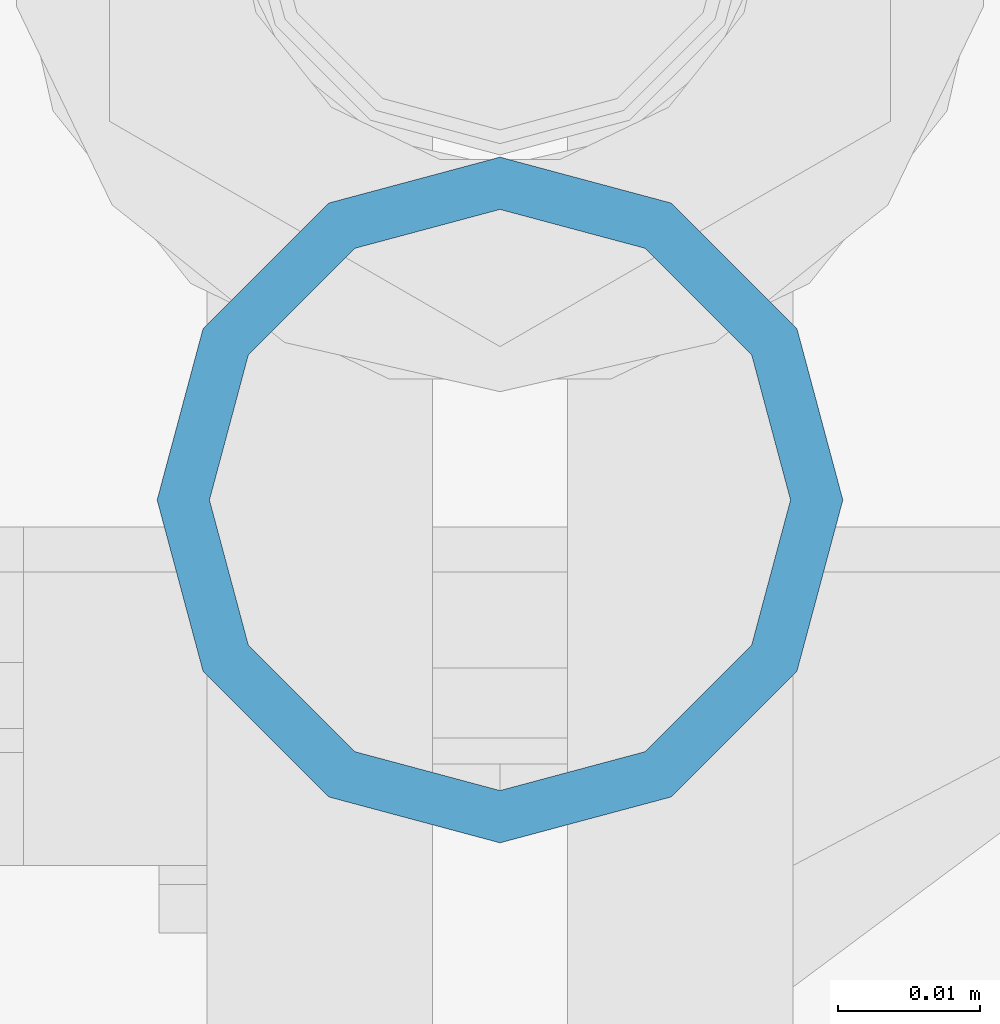
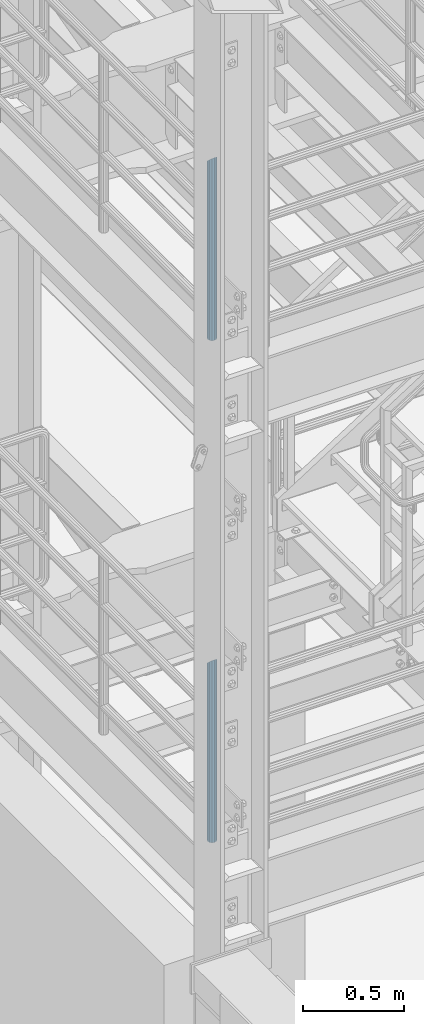
# One storey, part 564 of 1876: 2 columns, 2 elements without a shape of their own.
"""IFC2X3 building model written with IfcOpenShell, lengths in millimetres."""

from ifc_helpers import new_model, si_unit, frame, origin_with_axes, place, context, subcontext, project, spatial, faceted_brep, material, type_object, element, aggregate, save


model = new_model("IFC2X3")

# Units and contexts
model_context = context("Model", 3, precision=1e-05, world=origin_with_axes())
body_context = subcontext(model_context, "Body", "Model", "MODEL_VIEW")
ifc_project = project(units=[si_unit("LENGTHUNIT", "METRE", prefix="MILLI"), si_unit("AREAUNIT", "SQUARE_METRE"), si_unit("VOLUMEUNIT", "CUBIC_METRE"), si_unit("MASSUNIT", "GRAM", prefix="KILO"), si_unit("TIMEUNIT", "SECOND"), si_unit("PLANEANGLEUNIT", "RADIAN"), si_unit("SOLIDANGLEUNIT", "STERADIAN"), si_unit("THERMODYNAMICTEMPERATUREUNIT", "DEGREE_CELSIUS"), si_unit("LUMINOUSINTENSITYUNIT", "LUMEN")], contexts=[model_context])

# Site, building, storey
site_placement = place(None, origin_with_axes())
site = spatial("IfcSite", under=ifc_project, at=site_placement, CompositionType="ELEMENT")
building_placement = place(site_placement, origin_with_axes())
building = spatial("IfcBuilding", under=site, at=building_placement, Name="Undefined", CompositionType="ELEMENT")
storey_placement = place(building_placement, origin_with_axes())
storey = spatial("IfcBuildingStorey", under=building, at=storey_placement, Name="Undefined", CompositionType="ELEMENT", Elevation=0.0)

# Assembly, column
assembly_1_placement = place(storey_placement, origin_with_axes())
assembly_1 = element("IfcElementAssembly", 1, at=assembly_1_placement, inside=storey, Name="RAIL", AssemblyPlace="NOTDEFINED", PredefinedType="RIGID_FRAME")
ifc_material = material()
column_type = type_object("IfcColumnType", Name="PIPE1-1/2SCH40", PredefinedType="NOTDEFINED")
column_1_placement = place(assembly_1_placement, frame((2.72848410531878e-12, -6925.945, 8153.4), z_axis=(0.0, 1.0, 0.0), x_axis=(0.0, 0.0, 1.0)))
column_1 = element("IfcColumn", 2, at=column_1_placement, type_object=column_type, material=ifc_material, Name="POST", ObjectType="PIPE1-1/2SCH40", context=body_context, shape_type="Brep", body=[
    faceted_brep([(0.0, -20.4469999999999, 0.0), (0.0, -17.7076214311803, 10.2235000000001), (1066.1015, -17.7076214311803, 10.2235000000001), (1076.325, -20.4469999999999, 0.0), (0.0, -10.2235000000001, 17.7076214311801), (1058.61737856882, -10.2235000000001, 17.7076214311801), (-1.45519152283669e-11, 0.0, 20.4470000000001), (1055.878, 0.0, 20.4470000000001), (0.0, 10.2235000000001, 17.7076214311801), (1058.61737856882, 10.2235000000001, 17.7076214311801), (0.0, 17.7076214311803, 10.2235000000001), (1066.1015, 17.7076214311803, 10.2235000000001), (0.0, 20.4469999999999, 0.0), (1076.325, 20.4469999999999, 0.0), (0.0, 17.7076214311803, -10.2235000000001), (1086.5485, 17.7076214311803, -10.2235000000001), (0.0, 10.2235000000001, -17.7076214311801), (1094.03262143118, 10.2235000000001, -17.7076214311801), (-1.45519152283669e-11, 0.0, -20.4470000000001), (1096.772, 0.0, -20.4470000000001), (0.0, -10.2235000000001, -17.7076214311801), (1094.03262143118, -10.2235000000001, -17.7076214311801), (0.0, -17.7076214311803, -10.2235000000001), (1086.5485, -17.7076214311803, -10.2235000000001), (0.0, -24.1299999999992, 0.0), (0.0, -20.8971929933184, -12.0649999999996), (1088.39, -20.8971929933184, -12.0649999999996), (1076.325, -24.1300000000001, 0.0), (0.0, -12.0650000000001, -20.8971929933186), (1097.22219299332, -12.0650000000001, -20.8971929933186), (-1.45519152283669e-11, 0.0, -24.130000000001), (1100.455, 0.0, -24.1300000000001), (0.0, 12.0650000000001, -20.8971929933186), (1097.22219299332, 12.0650000000001, -20.8971929933186), (0.0, 20.8971929933184, -12.0649999999996), (1088.39, 20.8971929933184, -12.0649999999996), (0.0, 24.1299999999992, 0.0), (1076.325, 24.1300000000001, 0.0), (0.0, 20.8971929933184, 12.0649999999996), (1064.26, 20.8971929933184, 12.0649999999996), (0.0, 12.0650000000001, 20.8971929933186), (1055.42780700668, 12.0650000000001, 20.8971929933186), (-1.45519152283669e-11, 0.0, 24.130000000001), (1052.195, 0.0, 24.1300000000001), (0.0, -12.0650000000001, 20.8971929933186), (1055.42780700668, -12.0650000000001, 20.8971929933186), (0.0, -20.8971929933184, 12.0649999999996), (1064.26, -20.8971929933184, 12.0649999999996)], [[[0, 1, 2, 3]], [[1, 4, 5, 2]], [[4, 6, 7, 5]], [[6, 8, 9, 7]], [[8, 10, 11, 9]], [[10, 12, 13, 11]], [[12, 14, 15, 13]], [[14, 16, 17, 15]], [[16, 18, 19, 17]], [[18, 20, 21, 19]], [[20, 22, 23, 21]], [[22, 0, 3, 23]], [[24, 25, 26, 27]], [[25, 28, 29, 26]], [[28, 30, 31, 29]], [[30, 32, 33, 31]], [[32, 34, 35, 33]], [[34, 36, 37, 35]], [[36, 38, 39, 37]], [[38, 40, 41, 39]], [[40, 42, 43, 41]], [[42, 44, 45, 43]], [[44, 46, 47, 45]], [[46, 24, 27, 47]], [[29, 31, 33, 35, 37, 39, 41, 43, 45, 47, 27, 26], [5, 7, 9, 11, 13, 15, 17, 19, 21, 23, 3, 2]], [[46, 44, 42, 40, 38, 36, 34, 32, 30, 28, 25, 24], [22, 20, 18, 16, 14, 12, 10, 8, 6, 4, 1, 0]]]),
])
aggregate(assembly_1, [column_1])

assembly_2_placement = place(storey_placement, origin_with_axes())
assembly_2 = element("IfcElementAssembly", 3, at=assembly_2_placement, inside=storey, Name="RAIL", AssemblyPlace="NOTDEFINED", PredefinedType="RIGID_FRAME")
column_2_placement = place(assembly_2_placement, frame((2.72848410531878e-12, -6925.945, 5130.80000212598), z_axis=(0.0, 1.0, 0.0), x_axis=(0.0, 0.0, 1.0)))
column_2 = element("IfcColumn", 4, at=column_2_placement, type_object=column_type, material=ifc_material, Name="POST", ObjectType="PIPE1-1/2SCH40", context=body_context, shape_type="Brep", body=[
    faceted_brep([(0.0, -20.4469999999999, 0.0), (0.0, -17.7076214311803, 10.2235000000001), (1066.1015, -17.7076214311803, 10.2235000000001), (1076.325, -20.4469999999999, 0.0), (0.0, -10.2235000000001, 17.7076214311801), (1058.61737856882, -10.2235000000001, 17.7076214311801), (-1.45519152283669e-11, 0.0, 20.4470000000001), (1055.878, 0.0, 20.4470000000001), (0.0, 10.2235000000001, 17.7076214311801), (1058.61737856882, 10.2235000000001, 17.7076214311801), (0.0, 17.7076214311803, 10.2235000000001), (1066.1015, 17.7076214311803, 10.2235000000001), (0.0, 20.4469999999999, 0.0), (1076.325, 20.4469999999999, 0.0), (0.0, 17.7076214311803, -10.2235000000001), (1086.5485, 17.7076214311803, -10.2235000000001), (0.0, 10.2235000000001, -17.7076214311801), (1094.03262143118, 10.2235000000001, -17.7076214311801), (-1.45519152283669e-11, 0.0, -20.4470000000001), (1096.772, 0.0, -20.4470000000001), (0.0, -10.2235000000001, -17.7076214311801), (1094.03262143118, -10.2235000000001, -17.7076214311801), (0.0, -17.7076214311803, -10.2235000000001), (1086.5485, -17.7076214311803, -10.2235000000001), (0.0, -24.1299999999992, 0.0), (0.0, -20.8971929933184, -12.0649999999996), (1088.39, -20.8971929933184, -12.0649999999996), (1076.325, -24.1300000000001, 0.0), (0.0, -12.0650000000001, -20.8971929933186), (1097.22219299332, -12.0650000000001, -20.8971929933186), (-1.45519152283669e-11, 0.0, -24.130000000001), (1100.455, 0.0, -24.1300000000001), (0.0, 12.0650000000001, -20.8971929933186), (1097.22219299332, 12.0650000000001, -20.8971929933186), (0.0, 20.8971929933184, -12.0649999999996), (1088.39, 20.8971929933184, -12.0649999999996), (0.0, 24.1299999999992, 0.0), (1076.325, 24.1300000000001, 0.0), (0.0, 20.8971929933184, 12.0649999999996), (1064.26, 20.8971929933184, 12.0649999999996), (0.0, 12.0650000000001, 20.8971929933186), (1055.42780700668, 12.0650000000001, 20.8971929933186), (-1.45519152283669e-11, 0.0, 24.130000000001), (1052.195, 0.0, 24.1300000000001), (0.0, -12.0650000000001, 20.8971929933186), (1055.42780700668, -12.0650000000001, 20.8971929933186), (0.0, -20.8971929933184, 12.0649999999996), (1064.26, -20.8971929933184, 12.0649999999996)], [[[0, 1, 2, 3]], [[1, 4, 5, 2]], [[4, 6, 7, 5]], [[6, 8, 9, 7]], [[8, 10, 11, 9]], [[10, 12, 13, 11]], [[12, 14, 15, 13]], [[14, 16, 17, 15]], [[16, 18, 19, 17]], [[18, 20, 21, 19]], [[20, 22, 23, 21]], [[22, 0, 3, 23]], [[24, 25, 26, 27]], [[25, 28, 29, 26]], [[28, 30, 31, 29]], [[30, 32, 33, 31]], [[32, 34, 35, 33]], [[34, 36, 37, 35]], [[36, 38, 39, 37]], [[38, 40, 41, 39]], [[40, 42, 43, 41]], [[42, 44, 45, 43]], [[44, 46, 47, 45]], [[46, 24, 27, 47]], [[29, 31, 33, 35, 37, 39, 41, 43, 45, 47, 27, 26], [5, 7, 9, 11, 13, 15, 17, 19, 21, 23, 3, 2]], [[46, 44, 42, 40, 38, 36, 34, 32, 30, 28, 25, 24], [22, 20, 18, 16, 14, 12, 10, 8, 6, 4, 1, 0]]]),
])
aggregate(assembly_2, [column_2])

save(model, "model.ifc")
